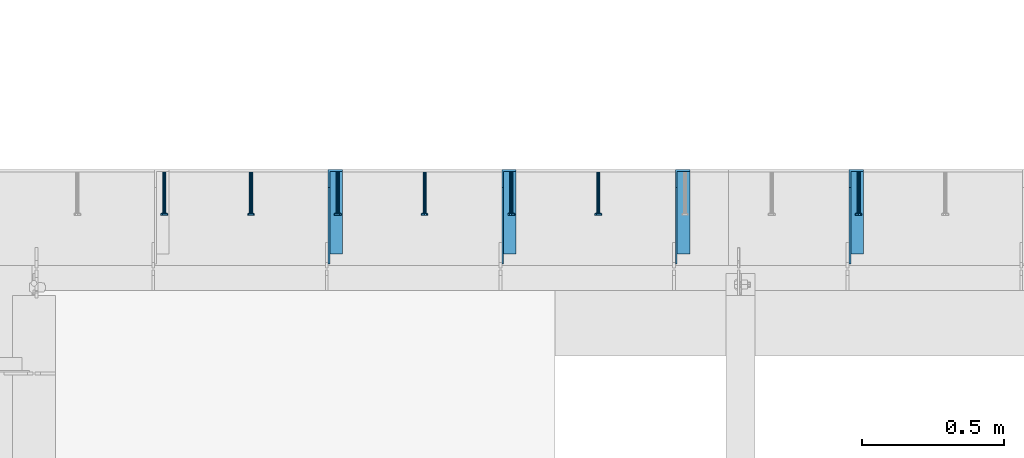
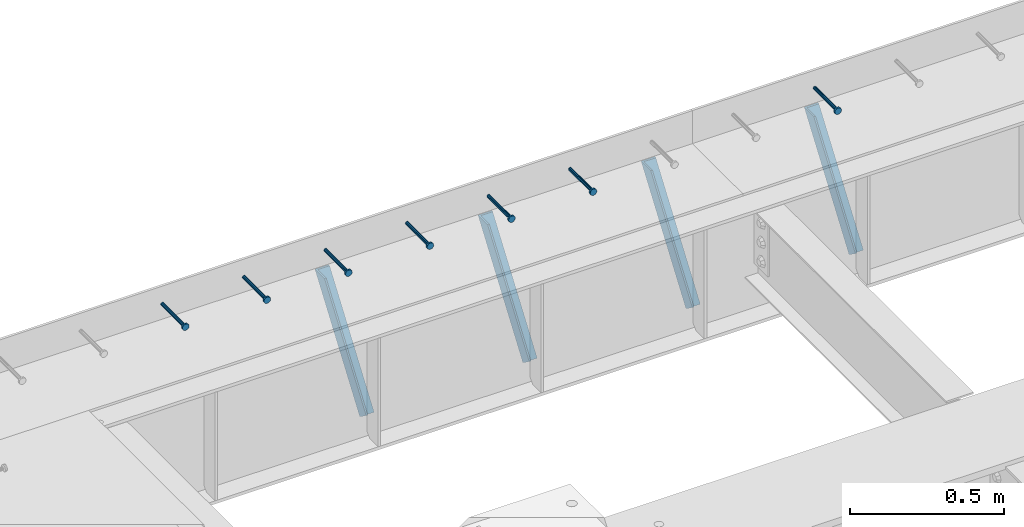
# One storey, part 1334 of 1763: 7 beams, 4 members, 8 elements without a shape of their own.
"""IFC2X3 building model written with IfcOpenShell, lengths in millimetres."""

from ifc_helpers import new_model, si_unit, frame, origin_with_axes, place, context, subcontext, project, spatial, faceted_brep, material, type_object, element, aggregate, save


model = new_model("IFC2X3")

# Units and contexts
model_context = context("Model", 3, precision=1e-05, world=origin_with_axes())
body_context = subcontext(model_context, "Body", "Model", "MODEL_VIEW")
ifc_project = project(units=[si_unit("LENGTHUNIT", "METRE", prefix="MILLI"), si_unit("AREAUNIT", "SQUARE_METRE"), si_unit("VOLUMEUNIT", "CUBIC_METRE"), si_unit("MASSUNIT", "GRAM", prefix="KILO"), si_unit("TIMEUNIT", "SECOND"), si_unit("PLANEANGLEUNIT", "RADIAN"), si_unit("SOLIDANGLEUNIT", "STERADIAN"), si_unit("THERMODYNAMICTEMPERATUREUNIT", "DEGREE_CELSIUS"), si_unit("LUMINOUSINTENSITYUNIT", "LUMEN")], contexts=[model_context])

# Site, building, storey
site_placement = place(None, origin_with_axes())
site = spatial("IfcSite", under=ifc_project, at=site_placement, CompositionType="ELEMENT")
building_placement = place(site_placement, origin_with_axes())
building = spatial("IfcBuilding", under=site, at=building_placement, Name="Undefined", CompositionType="ELEMENT")
storey_placement = place(building_placement, origin_with_axes())
storey = spatial("IfcBuildingStorey", under=building, at=storey_placement, Name="Undefined", CompositionType="ELEMENT", Elevation=0.0)

# Assembly, beam
assembly_1_placement = place(storey_placement, origin_with_axes())
assembly_1 = element("IfcElementAssembly", 1, at=assembly_1_placement, inside=storey, Name="HEADED STUD ANCHOR", AssemblyPlace="NOTDEFINED", PredefinedType="RIGID_FRAME")
ifc_material_1 = material(Name="STEEL/A108")
beam_type = type_object("IfcBeamType", PredefinedType="NOTDEFINED")
beam_1_placement = place(assembly_1_placement, frame((-84479.8372736983, 53984.5250183106, 5264.23140606069), z_axis=(0.0, 0.0, 1.0), x_axis=(0.0, -1.0, 0.0)))
beam_1 = element("IfcBeam", 2, at=beam_1_placement, type_object=beam_type, material=ifc_material_1, Name="HEADED STUD ANCHOR", context=body_context, shape_type="Brep", body=[
    faceted_brep([(0.0, -3.1800000667572, 5.5), (0.0, -5.5, 3.1800000667572), (141.732000000002, -5.5, 3.1800000667572), (141.732000000002, -3.1800000667572, 5.5), (0.0, -6.34999999999491, 1.45519152283669e-11), (141.732000000002, -6.34999990463257, 0.0), (0.0, -5.5, -3.1800000667572), (141.732000000002, -5.5, -3.1800000667572), (0.0, -3.1800000667572, -5.5), (141.732000000002, -3.1800000667572, -5.5), (0.0, 0.0, -6.34999990463257), (141.732000000002, 0.0, -6.34999990463257), (0.0, 3.1800000667572, -5.5), (141.732000000002, 3.1800000667572, -5.5), (0.0, 5.5, -3.1800000667572), (141.732000000002, 5.5, -3.1800000667572), (0.0, 6.34999999999491, -2.91038304567337e-11), (141.732000000002, 6.34999990463257, 0.0), (0.0, 5.5, 3.1800000667572), (141.732000000002, 5.5, 3.1800000667572), (0.0, 3.1800000667572, 5.5), (141.732000000002, 3.1800000667572, 5.5), (0.0, 0.0, 6.34999990463257), (141.732000000002, 0.0, 6.34999990463257), (144.780000000001, -10.9899997711182, 6.34999990463257), (144.780000000001, -6.34000015258789, 10.9899997711182), (144.780000000001, -12.6999998092651, 0.0), (144.780000000001, -10.9899997711182, -6.34999990463257), (144.780000000001, -6.34000015258789, -10.9899997711182), (144.780000000001, 0.0, -12.6899995803833), (144.780000000001, 6.34000015258789, -10.9899997711182), (144.780000000001, 10.9899997711182, -6.34999990463257), (144.780000000001, 12.6999998092651, 0.0), (144.780000000001, 10.9899997711182, 6.34999990463257), (144.780000000001, 6.34000015258789, 10.9899997711182), (144.780000000001, 0.0, 12.6899995803833), (152.400000000001, -10.9899997711182, 6.34999990463257), (152.400000000001, -6.34000015258789, 10.9899997711182), (152.400000000001, -12.6999998092651, 0.0), (152.400000000001, -10.9899997711182, -6.34999990463257), (152.400000000001, -6.34000015258789, -10.9899997711182), (152.400000000001, 0.0, -12.6899995803833), (152.400000000001, 6.34000015258789, -10.9899997711182), (152.400000000001, 10.9899997711182, -6.34999990463257), (152.400000000001, 12.6999998092651, 0.0), (152.400000000001, 10.9899997711182, 6.34999990463257), (152.400000000001, 6.34000015258789, 10.9899997711182), (152.400000000001, 0.0, 12.6899995803833)], [[[0, 1, 2, 3]], [[1, 4, 5, 2]], [[4, 6, 7, 5]], [[6, 8, 9, 7]], [[8, 10, 11, 9]], [[10, 12, 13, 11]], [[12, 14, 15, 13]], [[14, 16, 17, 15]], [[16, 18, 19, 17]], [[18, 20, 21, 19]], [[20, 22, 23, 21]], [[22, 0, 3, 23]], [[22, 20, 18, 16, 14, 12, 10, 8, 6, 4, 1, 0]], [[3, 2, 24, 25]], [[2, 5, 26, 24]], [[5, 7, 27, 26]], [[7, 9, 28, 27]], [[9, 11, 29, 28]], [[11, 13, 30, 29]], [[13, 15, 31, 30]], [[15, 17, 32, 31]], [[17, 19, 33, 32]], [[19, 21, 34, 33]], [[21, 23, 35, 34]], [[23, 3, 25, 35]], [[25, 24, 36, 37]], [[24, 26, 38, 36]], [[26, 27, 39, 38]], [[27, 28, 40, 39]], [[28, 29, 41, 40]], [[29, 30, 42, 41]], [[30, 31, 43, 42]], [[31, 32, 44, 43]], [[32, 33, 45, 44]], [[33, 34, 46, 45]], [[34, 35, 47, 46]], [[35, 25, 37, 47]], [[38, 39, 40, 41, 42, 43, 44, 45, 46, 47, 37, 36]]]),
])
aggregate(assembly_1, [beam_1])

assembly_2_placement = place(storey_placement, origin_with_axes())
assembly_2 = element("IfcElementAssembly", 3, at=assembly_2_placement, inside=storey, Name="HEADED STUD ANCHOR", AssemblyPlace="NOTDEFINED", PredefinedType="RIGID_FRAME")
beam_2_placement = place(assembly_2_placement, frame((-85394.2372736984, 53984.5250183106, 5264.23140606069), z_axis=(0.0, 0.0, 1.0), x_axis=(0.0, -1.0, 0.0)))
beam_2 = element("IfcBeam", 4, at=beam_2_placement, type_object=beam_type, material=ifc_material_1, Name="HEADED STUD ANCHOR", context=body_context, shape_type="Brep", body=[
    faceted_brep([(0.0, -3.1800000667572, 5.5), (0.0, -5.5, 3.1800000667572), (141.732000000002, -5.5, 3.1800000667572), (141.732000000002, -3.1800000667572, 5.5), (0.0, -6.34999999999491, 1.45519152283669e-11), (141.732000000002, -6.34999990463257, 0.0), (0.0, -5.5, -3.1800000667572), (141.732000000002, -5.5, -3.1800000667572), (0.0, -3.1800000667572, -5.5), (141.732000000002, -3.1800000667572, -5.5), (0.0, 0.0, -6.34999990463257), (141.732000000002, 0.0, -6.34999990463257), (0.0, 3.1800000667572, -5.5), (141.732000000002, 3.1800000667572, -5.5), (0.0, 5.5, -3.1800000667572), (141.732000000002, 5.5, -3.1800000667572), (0.0, 6.34999999999491, -2.91038304567337e-11), (141.732000000002, 6.34999990463257, 0.0), (0.0, 5.5, 3.1800000667572), (141.732000000002, 5.5, 3.1800000667572), (0.0, 3.1800000667572, 5.5), (141.732000000002, 3.1800000667572, 5.5), (0.0, 0.0, 6.34999990463257), (141.732000000002, 0.0, 6.34999990463257), (144.780000000001, -10.9899997711182, 6.34999990463257), (144.780000000001, -6.34000015258789, 10.9899997711182), (144.780000000001, -12.6999998092651, 0.0), (144.780000000001, -10.9899997711182, -6.34999990463257), (144.780000000001, -6.34000015258789, -10.9899997711182), (144.780000000001, 0.0, -12.6899995803833), (144.780000000001, 6.34000015258789, -10.9899997711182), (144.780000000001, 10.9899997711182, -6.34999990463257), (144.780000000001, 12.6999998092651, 0.0), (144.780000000001, 10.9899997711182, 6.34999990463257), (144.780000000001, 6.34000015258789, 10.9899997711182), (144.780000000001, 0.0, 12.6899995803833), (152.400000000001, -10.9899997711182, 6.34999990463257), (152.400000000001, -6.34000015258789, 10.9899997711182), (152.400000000001, -12.6999998092651, 0.0), (152.400000000001, -10.9899997711182, -6.34999990463257), (152.400000000001, -6.34000015258789, -10.9899997711182), (152.400000000001, 0.0, -12.6899995803833), (152.400000000001, 6.34000015258789, -10.9899997711182), (152.400000000001, 10.9899997711182, -6.34999990463257), (152.400000000001, 12.6999998092651, 0.0), (152.400000000001, 10.9899997711182, 6.34999990463257), (152.400000000001, 6.34000015258789, 10.9899997711182), (152.400000000001, 0.0, 12.6899995803833)], [[[0, 1, 2, 3]], [[1, 4, 5, 2]], [[4, 6, 7, 5]], [[6, 8, 9, 7]], [[8, 10, 11, 9]], [[10, 12, 13, 11]], [[12, 14, 15, 13]], [[14, 16, 17, 15]], [[16, 18, 19, 17]], [[18, 20, 21, 19]], [[20, 22, 23, 21]], [[22, 0, 3, 23]], [[22, 20, 18, 16, 14, 12, 10, 8, 6, 4, 1, 0]], [[3, 2, 24, 25]], [[2, 5, 26, 24]], [[5, 7, 27, 26]], [[7, 9, 28, 27]], [[9, 11, 29, 28]], [[11, 13, 30, 29]], [[13, 15, 31, 30]], [[15, 17, 32, 31]], [[17, 19, 33, 32]], [[19, 21, 34, 33]], [[21, 23, 35, 34]], [[23, 3, 25, 35]], [[25, 24, 36, 37]], [[24, 26, 38, 36]], [[26, 27, 39, 38]], [[27, 28, 40, 39]], [[28, 29, 41, 40]], [[29, 30, 42, 41]], [[30, 31, 43, 42]], [[31, 32, 44, 43]], [[32, 33, 45, 44]], [[33, 34, 46, 45]], [[34, 35, 47, 46]], [[35, 25, 37, 47]], [[38, 39, 40, 41, 42, 43, 44, 45, 46, 47, 37, 36]]]),
])
aggregate(assembly_2, [beam_2])

assembly_3_placement = place(storey_placement, origin_with_axes())
assembly_3 = element("IfcElementAssembly", 5, at=assembly_3_placement, inside=storey, Name="HEADED STUD ANCHOR", AssemblyPlace="NOTDEFINED", PredefinedType="RIGID_FRAME")
beam_3_placement = place(assembly_3_placement, frame((-85699.0372736983, 53984.5250183106, 5264.23140606069), z_axis=(0.0, 0.0, 1.0), x_axis=(0.0, -1.0, 0.0)))
beam_3 = element("IfcBeam", 6, at=beam_3_placement, type_object=beam_type, material=ifc_material_1, Name="HEADED STUD ANCHOR", context=body_context, shape_type="Brep", body=[
    faceted_brep([(0.0, -3.1800000667572, 5.5), (0.0, -5.5, 3.1800000667572), (141.732000000002, -5.5, 3.1800000667572), (141.732000000002, -3.1800000667572, 5.5), (0.0, -6.34999999999491, 1.45519152283669e-11), (141.732000000002, -6.34999990463257, 0.0), (0.0, -5.5, -3.1800000667572), (141.732000000002, -5.5, -3.1800000667572), (0.0, -3.1800000667572, -5.5), (141.732000000002, -3.1800000667572, -5.5), (0.0, 0.0, -6.34999990463257), (141.732000000002, 0.0, -6.34999990463257), (0.0, 3.1800000667572, -5.5), (141.732000000002, 3.1800000667572, -5.5), (0.0, 5.5, -3.1800000667572), (141.732000000002, 5.5, -3.1800000667572), (0.0, 6.34999999999491, -2.91038304567337e-11), (141.732000000002, 6.34999990463257, 0.0), (0.0, 5.5, 3.1800000667572), (141.732000000002, 5.5, 3.1800000667572), (0.0, 3.1800000667572, 5.5), (141.732000000002, 3.1800000667572, 5.5), (0.0, 0.0, 6.34999990463257), (141.732000000002, 0.0, 6.34999990463257), (144.780000000001, -10.9899997711182, 6.34999990463257), (144.780000000001, -6.34000015258789, 10.9899997711182), (144.780000000001, -12.6999998092651, 0.0), (144.780000000001, -10.9899997711182, -6.34999990463257), (144.780000000001, -6.34000015258789, -10.9899997711182), (144.780000000001, 0.0, -12.6899995803833), (144.780000000001, 6.34000015258789, -10.9899997711182), (144.780000000001, 10.9899997711182, -6.34999990463257), (144.780000000001, 12.6999998092651, 0.0), (144.780000000001, 10.9899997711182, 6.34999990463257), (144.780000000001, 6.34000015258789, 10.9899997711182), (144.780000000001, 0.0, 12.6899995803833), (152.400000000001, -10.9899997711182, 6.34999990463257), (152.400000000001, -6.34000015258789, 10.9899997711182), (152.400000000001, -12.6999998092651, 0.0), (152.400000000001, -10.9899997711182, -6.34999990463257), (152.400000000001, -6.34000015258789, -10.9899997711182), (152.400000000001, 0.0, -12.6899995803833), (152.400000000001, 6.34000015258789, -10.9899997711182), (152.400000000001, 10.9899997711182, -6.34999990463257), (152.400000000001, 12.6999998092651, 0.0), (152.400000000001, 10.9899997711182, 6.34999990463257), (152.400000000001, 6.34000015258789, 10.9899997711182), (152.400000000001, 0.0, 12.6899995803833)], [[[0, 1, 2, 3]], [[1, 4, 5, 2]], [[4, 6, 7, 5]], [[6, 8, 9, 7]], [[8, 10, 11, 9]], [[10, 12, 13, 11]], [[12, 14, 15, 13]], [[14, 16, 17, 15]], [[16, 18, 19, 17]], [[18, 20, 21, 19]], [[20, 22, 23, 21]], [[22, 0, 3, 23]], [[22, 20, 18, 16, 14, 12, 10, 8, 6, 4, 1, 0]], [[3, 2, 24, 25]], [[2, 5, 26, 24]], [[5, 7, 27, 26]], [[7, 9, 28, 27]], [[9, 11, 29, 28]], [[11, 13, 30, 29]], [[13, 15, 31, 30]], [[15, 17, 32, 31]], [[17, 19, 33, 32]], [[19, 21, 34, 33]], [[21, 23, 35, 34]], [[23, 3, 25, 35]], [[25, 24, 36, 37]], [[24, 26, 38, 36]], [[26, 27, 39, 38]], [[27, 28, 40, 39]], [[28, 29, 41, 40]], [[29, 30, 42, 41]], [[30, 31, 43, 42]], [[31, 32, 44, 43]], [[32, 33, 45, 44]], [[33, 34, 46, 45]], [[34, 35, 47, 46]], [[35, 25, 37, 47]], [[38, 39, 40, 41, 42, 43, 44, 45, 46, 47, 37, 36]]]),
])
aggregate(assembly_3, [beam_3])

assembly_4_placement = place(storey_placement, origin_with_axes())
assembly_4 = element("IfcElementAssembly", 7, at=assembly_4_placement, inside=storey, Name="HEADED STUD ANCHOR", AssemblyPlace="NOTDEFINED", PredefinedType="RIGID_FRAME")
beam_4_placement = place(assembly_4_placement, frame((-86003.8372736983, 53984.5250183106, 5264.23140606069), z_axis=(0.0, 0.0, 1.0), x_axis=(0.0, -1.0, 0.0)))
beam_4 = element("IfcBeam", 8, at=beam_4_placement, type_object=beam_type, material=ifc_material_1, Name="HEADED STUD ANCHOR", context=body_context, shape_type="Brep", body=[
    faceted_brep([(0.0, -3.1800000667572, 5.5), (0.0, -5.5, 3.1800000667572), (141.732000000002, -5.5, 3.1800000667572), (141.732000000002, -3.1800000667572, 5.5), (0.0, -6.34999999999491, 1.45519152283669e-11), (141.732000000002, -6.34999990463257, 0.0), (0.0, -5.5, -3.1800000667572), (141.732000000002, -5.5, -3.1800000667572), (0.0, -3.1800000667572, -5.5), (141.732000000002, -3.1800000667572, -5.5), (0.0, 0.0, -6.34999990463257), (141.732000000002, 0.0, -6.34999990463257), (0.0, 3.1800000667572, -5.5), (141.732000000002, 3.1800000667572, -5.5), (0.0, 5.5, -3.1800000667572), (141.732000000002, 5.5, -3.1800000667572), (0.0, 6.34999999999491, -2.91038304567337e-11), (141.732000000002, 6.34999990463257, 0.0), (0.0, 5.5, 3.1800000667572), (141.732000000002, 5.5, 3.1800000667572), (0.0, 3.1800000667572, 5.5), (141.732000000002, 3.1800000667572, 5.5), (0.0, 0.0, 6.34999990463257), (141.732000000002, 0.0, 6.34999990463257), (144.780000000001, -10.9899997711182, 6.34999990463257), (144.780000000001, -6.34000015258789, 10.9899997711182), (144.780000000001, -12.6999998092651, 0.0), (144.780000000001, -10.9899997711182, -6.34999990463257), (144.780000000001, -6.34000015258789, -10.9899997711182), (144.780000000001, 0.0, -12.6899995803833), (144.780000000001, 6.34000015258789, -10.9899997711182), (144.780000000001, 10.9899997711182, -6.34999990463257), (144.780000000001, 12.6999998092651, 0.0), (144.780000000001, 10.9899997711182, 6.34999990463257), (144.780000000001, 6.34000015258789, 10.9899997711182), (144.780000000001, 0.0, 12.6899995803833), (152.400000000001, -10.9899997711182, 6.34999990463257), (152.400000000001, -6.34000015258789, 10.9899997711182), (152.400000000001, -12.6999998092651, 0.0), (152.400000000001, -10.9899997711182, -6.34999990463257), (152.400000000001, -6.34000015258789, -10.9899997711182), (152.400000000001, 0.0, -12.6899995803833), (152.400000000001, 6.34000015258789, -10.9899997711182), (152.400000000001, 10.9899997711182, -6.34999990463257), (152.400000000001, 12.6999998092651, 0.0), (152.400000000001, 10.9899997711182, 6.34999990463257), (152.400000000001, 6.34000015258789, 10.9899997711182), (152.400000000001, 0.0, 12.6899995803833)], [[[0, 1, 2, 3]], [[1, 4, 5, 2]], [[4, 6, 7, 5]], [[6, 8, 9, 7]], [[8, 10, 11, 9]], [[10, 12, 13, 11]], [[12, 14, 15, 13]], [[14, 16, 17, 15]], [[16, 18, 19, 17]], [[18, 20, 21, 19]], [[20, 22, 23, 21]], [[22, 0, 3, 23]], [[22, 20, 18, 16, 14, 12, 10, 8, 6, 4, 1, 0]], [[3, 2, 24, 25]], [[2, 5, 26, 24]], [[5, 7, 27, 26]], [[7, 9, 28, 27]], [[9, 11, 29, 28]], [[11, 13, 30, 29]], [[13, 15, 31, 30]], [[15, 17, 32, 31]], [[17, 19, 33, 32]], [[19, 21, 34, 33]], [[21, 23, 35, 34]], [[23, 3, 25, 35]], [[25, 24, 36, 37]], [[24, 26, 38, 36]], [[26, 27, 39, 38]], [[27, 28, 40, 39]], [[28, 29, 41, 40]], [[29, 30, 42, 41]], [[30, 31, 43, 42]], [[31, 32, 44, 43]], [[32, 33, 45, 44]], [[33, 34, 46, 45]], [[34, 35, 47, 46]], [[35, 25, 37, 47]], [[38, 39, 40, 41, 42, 43, 44, 45, 46, 47, 37, 36]]]),
])
aggregate(assembly_4, [beam_4])

assembly_5_placement = place(storey_placement, origin_with_axes())
assembly_5 = element("IfcElementAssembly", 9, at=assembly_5_placement, inside=storey, Name="HEADED STUD ANCHOR", AssemblyPlace="NOTDEFINED", PredefinedType="RIGID_FRAME")
beam_5_placement = place(assembly_5_placement, frame((-86308.6372736983, 53984.5250183106, 5264.23140606069), z_axis=(0.0, 0.0, 1.0), x_axis=(0.0, -1.0, 0.0)))
beam_5 = element("IfcBeam", 10, at=beam_5_placement, type_object=beam_type, material=ifc_material_1, Name="HEADED STUD ANCHOR", context=body_context, shape_type="Brep", body=[
    faceted_brep([(0.0, -3.1800000667572, 5.5), (0.0, -5.5, 3.1800000667572), (141.732000000002, -5.5, 3.1800000667572), (141.732000000002, -3.1800000667572, 5.5), (0.0, -6.34999999999491, 1.45519152283669e-11), (141.732000000002, -6.34999990463257, 0.0), (0.0, -5.5, -3.1800000667572), (141.732000000002, -5.5, -3.1800000667572), (0.0, -3.1800000667572, -5.5), (141.732000000002, -3.1800000667572, -5.5), (0.0, 0.0, -6.34999990463257), (141.732000000002, 0.0, -6.34999990463257), (0.0, 3.1800000667572, -5.5), (141.732000000002, 3.1800000667572, -5.5), (0.0, 5.5, -3.1800000667572), (141.732000000002, 5.5, -3.1800000667572), (0.0, 6.34999999999491, -2.91038304567337e-11), (141.732000000002, 6.34999990463257, 0.0), (0.0, 5.5, 3.1800000667572), (141.732000000002, 5.5, 3.1800000667572), (0.0, 3.1800000667572, 5.5), (141.732000000002, 3.1800000667572, 5.5), (0.0, 0.0, 6.34999990463257), (141.732000000002, 0.0, 6.34999990463257), (144.780000000001, -10.9899997711182, 6.34999990463257), (144.780000000001, -6.34000015258789, 10.9899997711182), (144.780000000001, -12.6999998092651, 0.0), (144.780000000001, -10.9899997711182, -6.34999990463257), (144.780000000001, -6.34000015258789, -10.9899997711182), (144.780000000001, 0.0, -12.6899995803833), (144.780000000001, 6.34000015258789, -10.9899997711182), (144.780000000001, 10.9899997711182, -6.34999990463257), (144.780000000001, 12.6999998092651, 0.0), (144.780000000001, 10.9899997711182, 6.34999990463257), (144.780000000001, 6.34000015258789, 10.9899997711182), (144.780000000001, 0.0, 12.6899995803833), (152.400000000001, -10.9899997711182, 6.34999990463257), (152.400000000001, -6.34000015258789, 10.9899997711182), (152.400000000001, -12.6999998092651, 0.0), (152.400000000001, -10.9899997711182, -6.34999990463257), (152.400000000001, -6.34000015258789, -10.9899997711182), (152.400000000001, 0.0, -12.6899995803833), (152.400000000001, 6.34000015258789, -10.9899997711182), (152.400000000001, 10.9899997711182, -6.34999990463257), (152.400000000001, 12.6999998092651, 0.0), (152.400000000001, 10.9899997711182, 6.34999990463257), (152.400000000001, 6.34000015258789, 10.9899997711182), (152.400000000001, 0.0, 12.6899995803833)], [[[0, 1, 2, 3]], [[1, 4, 5, 2]], [[4, 6, 7, 5]], [[6, 8, 9, 7]], [[8, 10, 11, 9]], [[10, 12, 13, 11]], [[12, 14, 15, 13]], [[14, 16, 17, 15]], [[16, 18, 19, 17]], [[18, 20, 21, 19]], [[20, 22, 23, 21]], [[22, 0, 3, 23]], [[22, 20, 18, 16, 14, 12, 10, 8, 6, 4, 1, 0]], [[3, 2, 24, 25]], [[2, 5, 26, 24]], [[5, 7, 27, 26]], [[7, 9, 28, 27]], [[9, 11, 29, 28]], [[11, 13, 30, 29]], [[13, 15, 31, 30]], [[15, 17, 32, 31]], [[17, 19, 33, 32]], [[19, 21, 34, 33]], [[21, 23, 35, 34]], [[23, 3, 25, 35]], [[25, 24, 36, 37]], [[24, 26, 38, 36]], [[26, 27, 39, 38]], [[27, 28, 40, 39]], [[28, 29, 41, 40]], [[29, 30, 42, 41]], [[30, 31, 43, 42]], [[31, 32, 44, 43]], [[32, 33, 45, 44]], [[33, 34, 46, 45]], [[34, 35, 47, 46]], [[35, 25, 37, 47]], [[38, 39, 40, 41, 42, 43, 44, 45, 46, 47, 37, 36]]]),
])
aggregate(assembly_5, [beam_5])

assembly_6_placement = place(storey_placement, origin_with_axes())
assembly_6 = element("IfcElementAssembly", 11, at=assembly_6_placement, inside=storey, Name="HEADED STUD ANCHOR", AssemblyPlace="NOTDEFINED", PredefinedType="RIGID_FRAME")
beam_6_placement = place(assembly_6_placement, frame((-86613.4372736983, 53984.5250183106, 5264.23140606069), z_axis=(0.0, 0.0, 1.0), x_axis=(0.0, -1.0, 0.0)))
beam_6 = element("IfcBeam", 12, at=beam_6_placement, type_object=beam_type, material=ifc_material_1, Name="HEADED STUD ANCHOR", context=body_context, shape_type="Brep", body=[
    faceted_brep([(0.0, -3.1800000667572, 5.5), (0.0, -5.5, 3.1800000667572), (141.732000000002, -5.5, 3.1800000667572), (141.732000000002, -3.1800000667572, 5.5), (0.0, -6.34999999999491, 1.45519152283669e-11), (141.732000000002, -6.34999990463257, 0.0), (0.0, -5.5, -3.1800000667572), (141.732000000002, -5.5, -3.1800000667572), (0.0, -3.1800000667572, -5.5), (141.732000000002, -3.1800000667572, -5.5), (0.0, 0.0, -6.34999990463257), (141.732000000002, 0.0, -6.34999990463257), (0.0, 3.1800000667572, -5.5), (141.732000000002, 3.1800000667572, -5.5), (0.0, 5.5, -3.1800000667572), (141.732000000002, 5.5, -3.1800000667572), (0.0, 6.34999999999491, -2.91038304567337e-11), (141.732000000002, 6.34999990463257, 0.0), (0.0, 5.5, 3.1800000667572), (141.732000000002, 5.5, 3.1800000667572), (0.0, 3.1800000667572, 5.5), (141.732000000002, 3.1800000667572, 5.5), (0.0, 0.0, 6.34999990463257), (141.732000000002, 0.0, 6.34999990463257), (144.780000000001, -10.9899997711182, 6.34999990463257), (144.780000000001, -6.34000015258789, 10.9899997711182), (144.780000000001, -12.6999998092651, 0.0), (144.780000000001, -10.9899997711182, -6.34999990463257), (144.780000000001, -6.34000015258789, -10.9899997711182), (144.780000000001, 0.0, -12.6899995803833), (144.780000000001, 6.34000015258789, -10.9899997711182), (144.780000000001, 10.9899997711182, -6.34999990463257), (144.780000000001, 12.6999998092651, 0.0), (144.780000000001, 10.9899997711182, 6.34999990463257), (144.780000000001, 6.34000015258789, 10.9899997711182), (144.780000000001, 0.0, 12.6899995803833), (152.400000000001, -10.9899997711182, 6.34999990463257), (152.400000000001, -6.34000015258789, 10.9899997711182), (152.400000000001, -12.6999998092651, 0.0), (152.400000000001, -10.9899997711182, -6.34999990463257), (152.400000000001, -6.34000015258789, -10.9899997711182), (152.400000000001, 0.0, -12.6899995803833), (152.400000000001, 6.34000015258789, -10.9899997711182), (152.400000000001, 10.9899997711182, -6.34999990463257), (152.400000000001, 12.6999998092651, 0.0), (152.400000000001, 10.9899997711182, 6.34999990463257), (152.400000000001, 6.34000015258789, 10.9899997711182), (152.400000000001, 0.0, 12.6899995803833)], [[[0, 1, 2, 3]], [[1, 4, 5, 2]], [[4, 6, 7, 5]], [[6, 8, 9, 7]], [[8, 10, 11, 9]], [[10, 12, 13, 11]], [[12, 14, 15, 13]], [[14, 16, 17, 15]], [[16, 18, 19, 17]], [[18, 20, 21, 19]], [[20, 22, 23, 21]], [[22, 0, 3, 23]], [[22, 20, 18, 16, 14, 12, 10, 8, 6, 4, 1, 0]], [[3, 2, 24, 25]], [[2, 5, 26, 24]], [[5, 7, 27, 26]], [[7, 9, 28, 27]], [[9, 11, 29, 28]], [[11, 13, 30, 29]], [[13, 15, 31, 30]], [[15, 17, 32, 31]], [[17, 19, 33, 32]], [[19, 21, 34, 33]], [[21, 23, 35, 34]], [[23, 3, 25, 35]], [[25, 24, 36, 37]], [[24, 26, 38, 36]], [[26, 27, 39, 38]], [[27, 28, 40, 39]], [[28, 29, 41, 40]], [[29, 30, 42, 41]], [[30, 31, 43, 42]], [[31, 32, 44, 43]], [[32, 33, 45, 44]], [[33, 34, 46, 45]], [[34, 35, 47, 46]], [[35, 25, 37, 47]], [[38, 39, 40, 41, 42, 43, 44, 45, 46, 47, 37, 36]]]),
])
aggregate(assembly_6, [beam_6])

assembly_7_placement = place(storey_placement, origin_with_axes())
assembly_7 = element("IfcElementAssembly", 13, at=assembly_7_placement, inside=storey, Name="HEADED STUD ANCHOR", AssemblyPlace="NOTDEFINED", PredefinedType="RIGID_FRAME")
beam_7_placement = place(assembly_7_placement, frame((-86918.2372736984, 53984.5250183106, 5264.23140606069), z_axis=(0.0, 0.0, 1.0), x_axis=(0.0, -1.0, 0.0)))
beam_7 = element("IfcBeam", 14, at=beam_7_placement, type_object=beam_type, material=ifc_material_1, Name="HEADED STUD ANCHOR", context=body_context, shape_type="Brep", body=[
    faceted_brep([(0.0, -3.1800000667572, 5.5), (0.0, -5.5, 3.1800000667572), (141.732000000002, -5.5, 3.1800000667572), (141.732000000002, -3.1800000667572, 5.5), (0.0, -6.34999999999491, 1.45519152283669e-11), (141.732000000002, -6.34999990463257, 0.0), (0.0, -5.5, -3.1800000667572), (141.732000000002, -5.5, -3.1800000667572), (0.0, -3.1800000667572, -5.5), (141.732000000002, -3.1800000667572, -5.5), (0.0, 0.0, -6.34999990463257), (141.732000000002, 0.0, -6.34999990463257), (0.0, 3.1800000667572, -5.5), (141.732000000002, 3.1800000667572, -5.5), (0.0, 5.5, -3.1800000667572), (141.732000000002, 5.5, -3.1800000667572), (0.0, 6.34999999999491, -2.91038304567337e-11), (141.732000000002, 6.34999990463257, 0.0), (0.0, 5.5, 3.1800000667572), (141.732000000002, 5.5, 3.1800000667572), (0.0, 3.1800000667572, 5.5), (141.732000000002, 3.1800000667572, 5.5), (0.0, 0.0, 6.34999990463257), (141.732000000002, 0.0, 6.34999990463257), (144.780000000001, -10.9899997711182, 6.34999990463257), (144.780000000001, -6.34000015258789, 10.9899997711182), (144.780000000001, -12.6999998092651, 0.0), (144.780000000001, -10.9899997711182, -6.34999990463257), (144.780000000001, -6.34000015258789, -10.9899997711182), (144.780000000001, 0.0, -12.6899995803833), (144.780000000001, 6.34000015258789, -10.9899997711182), (144.780000000001, 10.9899997711182, -6.34999990463257), (144.780000000001, 12.6999998092651, 0.0), (144.780000000001, 10.9899997711182, 6.34999990463257), (144.780000000001, 6.34000015258789, 10.9899997711182), (144.780000000001, 0.0, 12.6899995803833), (152.400000000001, -10.9899997711182, 6.34999990463257), (152.400000000001, -6.34000015258789, 10.9899997711182), (152.400000000001, -12.6999998092651, 0.0), (152.400000000001, -10.9899997711182, -6.34999990463257), (152.400000000001, -6.34000015258789, -10.9899997711182), (152.400000000001, 0.0, -12.6899995803833), (152.400000000001, 6.34000015258789, -10.9899997711182), (152.400000000001, 10.9899997711182, -6.34999990463257), (152.400000000001, 12.6999998092651, 0.0), (152.400000000001, 10.9899997711182, 6.34999990463257), (152.400000000001, 6.34000015258789, 10.9899997711182), (152.400000000001, 0.0, 12.6899995803833)], [[[0, 1, 2, 3]], [[1, 4, 5, 2]], [[4, 6, 7, 5]], [[6, 8, 9, 7]], [[8, 10, 11, 9]], [[10, 12, 13, 11]], [[12, 14, 15, 13]], [[14, 16, 17, 15]], [[16, 18, 19, 17]], [[18, 20, 21, 19]], [[20, 22, 23, 21]], [[22, 0, 3, 23]], [[22, 20, 18, 16, 14, 12, 10, 8, 6, 4, 1, 0]], [[3, 2, 24, 25]], [[2, 5, 26, 24]], [[5, 7, 27, 26]], [[7, 9, 28, 27]], [[9, 11, 29, 28]], [[11, 13, 30, 29]], [[13, 15, 31, 30]], [[15, 17, 32, 31]], [[17, 19, 33, 32]], [[19, 21, 34, 33]], [[21, 23, 35, 34]], [[23, 3, 25, 35]], [[25, 24, 36, 37]], [[24, 26, 38, 36]], [[26, 27, 39, 38]], [[27, 28, 40, 39]], [[28, 29, 41, 40]], [[29, 30, 42, 41]], [[30, 31, 43, 42]], [[31, 32, 44, 43]], [[32, 33, 45, 44]], [[33, 34, 46, 45]], [[34, 35, 47, 46]], [[35, 25, 37, 47]], [[38, 39, 40, 41, 42, 43, 44, 45, 46, 47, 37, 36]]]),
])
aggregate(assembly_7, [beam_7])

# Assembly, members
assembly_8_placement = place(storey_placement, origin_with_axes())
assembly_8 = element("IfcElementAssembly", 15, at=assembly_8_placement, inside=storey, Name="BEAM", AssemblyPlace="NOTDEFINED", PredefinedType="RIGID_FRAME")
ifc_material_2 = material(Name="STEEL/A36")
member_type = type_object("IfcMemberType", Name="L2X2X1/4", PredefinedType="NOTDEFINED")
member_1_placement = place(assembly_8_placement, frame((-84488.1716486984, 53682.7083833994, 4801.55161052494), z_axis=(0.0, -0.814117947745209, 0.580699549818259), x_axis=(0.0, 0.58069954981826, 0.814117947745209)))
member_1 = element("IfcMember", 16, at=member_1_placement, type_object=member_type, material=ifc_material_2, Name="ANGLE", ObjectType="L2X2X1/4", context=body_context, shape_type="Brep", body=[
    faceted_brep([(-1.45519152283669e-11, 25.4000000000015, -25.3999999999869), (1.45519152283669e-11, 25.4000000000015, 25.3999999999796), (464.304493432646, 25.4000000000015, 25.3999999991429), (500.539460322936, 25.4000000000015, -25.4000000009546), (1.45519152283669e-11, 19.0499999999993, 25.3999999999796), (464.304493432646, 19.0500000000029, 25.3999999991429), (-7.27595761418343e-12, 19.0499999999993, -19.0499999999956), (496.010089461648, 19.0500000000029, -19.0500000009415), (-7.27595761418343e-12, -25.4000000000015, -19.0499999999956), (496.010089461648, -25.4000000000015, -19.0500000009415), (-1.45519152283669e-11, -25.4000000000015, -25.3999999999869), (500.539460322936, -25.4000000000015, -25.4000000009546)], [[[0, 1, 2, 3]], [[1, 4, 5, 2]], [[4, 6, 7, 5]], [[6, 8, 9, 7]], [[8, 10, 11, 9]], [[10, 0, 3, 11]], [[5, 7, 9, 11, 3, 2]], [[10, 8, 6, 4, 1, 0]]]),
])
member_2_placement = place(assembly_8_placement, frame((-85707.3716486984, 53682.7083833994, 4801.55161052494), z_axis=(0.0, -0.814117947745209, 0.580699549818259), x_axis=(0.0, 0.58069954981826, 0.814117947745209)))
member_2 = element("IfcMember", 17, at=member_2_placement, type_object=member_type, material=ifc_material_2, Name="ANGLE", ObjectType="L2X2X1/4", context=body_context, shape_type="Brep", body=[
    faceted_brep([(-1.45519152283669e-11, 25.4000000000015, -25.3999999999869), (1.45519152283669e-11, 25.4000000000015, 25.3999999999796), (464.304493432646, 25.4000000000015, 25.3999999991429), (500.539460322936, 25.4000000000015, -25.4000000009546), (1.45519152283669e-11, 19.0499999999993, 25.3999999999796), (464.304493432646, 19.0500000000029, 25.3999999991429), (-7.27595761418343e-12, 19.0499999999993, -19.0499999999956), (496.010089461648, 19.0500000000029, -19.0500000009415), (-7.27595761418343e-12, -25.4000000000015, -19.0499999999956), (496.010089461648, -25.4000000000015, -19.0500000009415), (-1.45519152283669e-11, -25.4000000000015, -25.3999999999869), (500.539460322936, -25.4000000000015, -25.4000000009546)], [[[0, 1, 2, 3]], [[1, 4, 5, 2]], [[4, 6, 7, 5]], [[6, 8, 9, 7]], [[8, 10, 11, 9]], [[10, 0, 3, 11]], [[5, 7, 9, 11, 3, 2]], [[10, 8, 6, 4, 1, 0]]]),
])
member_3_placement = place(assembly_8_placement, frame((-85097.7716486984, 53682.7083833994, 4801.55161052494), z_axis=(0.0, -0.814117947745209, 0.580699549818259), x_axis=(0.0, 0.58069954981826, 0.814117947745209)))
member_3 = element("IfcMember", 18, at=member_3_placement, type_object=member_type, material=ifc_material_2, Name="ANGLE", ObjectType="L2X2X1/4", context=body_context, shape_type="Brep", body=[
    faceted_brep([(-1.45519152283669e-11, 25.4000000000015, -25.3999999999869), (1.45519152283669e-11, 25.4000000000015, 25.3999999999796), (464.304493432646, 25.4000000000015, 25.3999999991429), (500.539460322936, 25.4000000000015, -25.4000000009546), (1.45519152283669e-11, 19.0499999999993, 25.3999999999796), (464.304493432646, 19.0500000000029, 25.3999999991429), (-7.27595761418343e-12, 19.0499999999993, -19.0499999999956), (496.010089461648, 19.0500000000029, -19.0500000009415), (-7.27595761418343e-12, -25.4000000000015, -19.0499999999956), (496.010089461648, -25.4000000000015, -19.0500000009415), (-1.45519152283669e-11, -25.4000000000015, -25.3999999999869), (500.539460322936, -25.4000000000015, -25.4000000009546)], [[[0, 1, 2, 3]], [[1, 4, 5, 2]], [[4, 6, 7, 5]], [[6, 8, 9, 7]], [[8, 10, 11, 9]], [[10, 0, 3, 11]], [[5, 7, 9, 11, 3, 2]], [[10, 8, 6, 4, 1, 0]]]),
])
member_4_placement = place(assembly_8_placement, frame((-86316.9716486984, 53682.7083833994, 4801.55161052494), z_axis=(0.0, -0.814117947745209, 0.580699549818259), x_axis=(0.0, 0.58069954981826, 0.814117947745209)))
member_4 = element("IfcMember", 19, at=member_4_placement, type_object=member_type, material=ifc_material_2, Name="ANGLE", ObjectType="L2X2X1/4", context=body_context, shape_type="Brep", body=[
    faceted_brep([(-1.45519152283669e-11, 25.4000000000015, -25.3999999999869), (1.45519152283669e-11, 25.4000000000015, 25.3999999999796), (464.304493432646, 25.4000000000015, 25.3999999991429), (500.539460322936, 25.4000000000015, -25.4000000009546), (1.45519152283669e-11, 19.0499999999993, 25.3999999999796), (464.304493432646, 19.0500000000029, 25.3999999991429), (-7.27595761418343e-12, 19.0499999999993, -19.0499999999956), (496.010089461648, 19.0500000000029, -19.0500000009415), (-7.27595761418343e-12, -25.4000000000015, -19.0499999999956), (496.010089461648, -25.4000000000015, -19.0500000009415), (-1.45519152283669e-11, -25.4000000000015, -25.3999999999869), (500.539460322936, -25.4000000000015, -25.4000000009546)], [[[0, 1, 2, 3]], [[1, 4, 5, 2]], [[4, 6, 7, 5]], [[6, 8, 9, 7]], [[8, 10, 11, 9]], [[10, 0, 3, 11]], [[5, 7, 9, 11, 3, 2]], [[10, 8, 6, 4, 1, 0]]]),
])
aggregate(assembly_8, [member_1, member_2, member_3, member_4])

save(model, "model.ifc")
